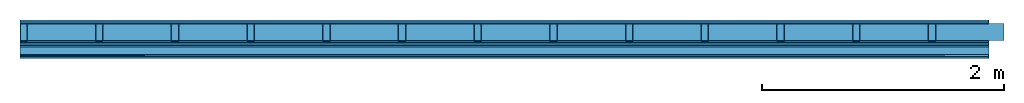
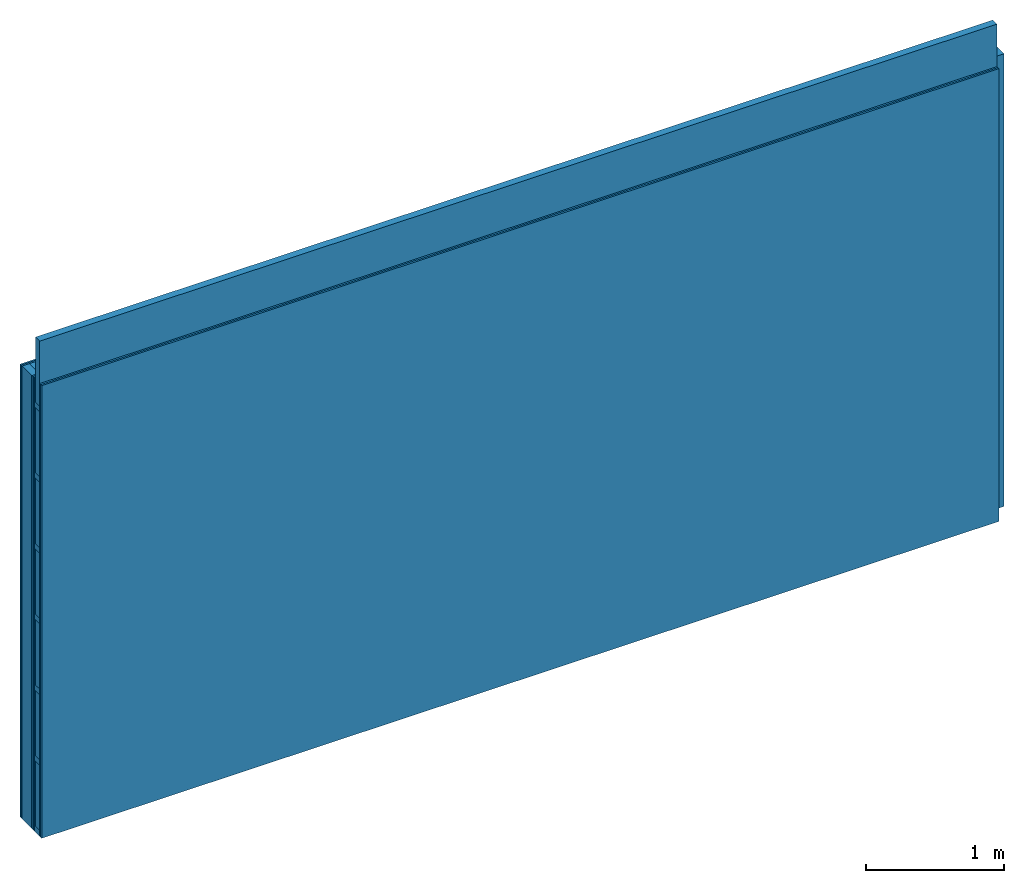
# One storey: 7 plates, 4 members, 1 element without a shape of its own.
"""IFC4 building model written with IfcOpenShell, lengths in metres."""

from ifc_helpers import new_model, si_unit, derived_unit, direction, frame, frame_2d, origin, origin_with_axes, place, context, project, spatial, rectangle, extrude, material, layer, layer_set, type_object, element, aggregate, save


model = new_model("IFC4")

# Units and contexts
plan_context = context("Plan", 3, precision=1e-05, world=origin(), true_north=direction((0.0, 1.0)))
model_context = context("Model", 3, precision=1e-05, world=origin(), true_north=direction((0.0, 1.0)))
ifc_project = project(units=[si_unit("LENGTHUNIT", "METRE"), derived_unit("SOUNDPRESSUREUNIT", [(si_unit("PRESSUREUNIT", "PASCAL", prefix="MICRO"), 0)]), si_unit("ENERGYUNIT", "JOULE", prefix="MEGA"), si_unit("MASSUNIT", "GRAM", prefix="KILO"), derived_unit("THERMALTRANSMITTANCEUNIT", [(si_unit("POWERUNIT", "WATT"), 1), (si_unit("AREAUNIT", "SQUARE_METRE"), -1), (si_unit("THERMODYNAMICTEMPERATUREUNIT", "KELVIN"), -1)]), derived_unit("AREADENSITYUNIT", [(si_unit("MASSUNIT", "GRAM", prefix="KILO"), 1), (si_unit("AREAUNIT", "SQUARE_METRE"), -1)]), derived_unit("USERDEFINED", [(si_unit("ENERGYUNIT", "JOULE", prefix="MEGA"), 1), (si_unit("AREAUNIT", "SQUARE_METRE"), -1)])], contexts=[plan_context, model_context])

# Site, building, storey
site = spatial("IfcSite", under=ifc_project)
building_placement = place(None, origin())
building = spatial("IfcBuilding", under=site, at=building_placement)
storey_placement = place(building_placement, origin())
storey = spatial("IfcBuildingStorey", under=building, at=storey_placement)

# Wall, members, plates
ifc_material_1 = material(Name="Glued joints")
ifc_layer_1 = layer(ifc_material_1, 0.0, Name="Surface")
ifc_material_2 = material(Category="03.007")
ifc_layer_2 = layer(ifc_material_2, 0.015, Name="2nd layer")
ifc_layer_3 = layer(ifc_material_2, 0.015, Name="1st layer")
ifc_material_3 = material(Name="of the art")
ifc_layer_4 = layer(ifc_material_3, 0.0, Name="Bond")
ifc_layer_5 = layer(None, 0.14, Name="Support")
ifc_layer_6 = layer(ifc_material_3, 0.0, Name="Bond")
ifc_layer_7 = layer(ifc_material_2, 0.015, Name="1st layer")
ifc_layer_8 = layer(ifc_material_2, 0.015, Name="2nd layer")
ifc_material_4 = material(Name="Air")
ifc_layer_9 = layer(ifc_material_4, 0.01, Name="Coupling")
ifc_layer_10 = layer(None, 0.075, Name="Battens / profiles")
ifc_material_5 = material(Name="Plasterboard type A", Category="03.008")
ifc_layer_11 = layer(ifc_material_5, 0.015, Name="Covering 1st layer")
ifc_layer_12 = layer(ifc_material_5, 0.015, Name="Covering 2nd layer")
ifc_material_6 = material(Name="joints", Category="04.017")
ifc_layer_13 = layer(ifc_material_6, 0.0, Name="Surface")
ifc_layer_set = layer_set([ifc_layer_1, ifc_layer_2, ifc_layer_3, ifc_layer_4, ifc_layer_5, ifc_layer_6, ifc_layer_7, ifc_layer_8, ifc_layer_9, ifc_layer_10, ifc_layer_11, ifc_layer_12, ifc_layer_13])
wall_type = type_object("IfcWallType", Name="C0095", PredefinedType="NOTDEFINED", material=ifc_layer_set)
wall_placement = place(None, frame((0.0, 0.0, 0.0), z_axis=(0.0, -1.0, 0.0), x_axis=(1.0, 0.0, 0.0)))
wall = element("IfcWall", 1, at=wall_placement, inside=storey, type_object=wall_type, material=ifc_layer_set, Name="Wall #1")
ifc_material_7 = material()
member_1_placement = place(wall_placement, origin())
member_1 = element("IfcMember", 2, at=member_1_placement, material=ifc_material_7, Name="Support", context=plan_context, shape_type="SweptSolid", body=[
    extrude(rectangle(XDim=0.06, YDim=0.14, at=frame_2d((0.03, 0.07), x_axis=(1.0, 0.0))), frame((0.0, 4.0, 0.03), z_axis=(0.0, -1.0, 0.0), x_axis=(1.0, 0.0, 0.0)), (0.0, 0.0, 1.0), 4.0),
    extrude(rectangle(XDim=0.06, YDim=0.14, at=frame_2d((0.03, 0.07), x_axis=(1.0, 0.0))), frame((0.625, 4.0, 0.03), z_axis=(0.0, -1.0, 0.0), x_axis=(1.0, 0.0, 0.0)), (0.0, 0.0, 1.0), 4.0),
    extrude(rectangle(XDim=0.06, YDim=0.14, at=frame_2d((0.03, 0.07), x_axis=(1.0, 0.0))), frame((1.25, 4.0, 0.03), z_axis=(0.0, -1.0, 0.0), x_axis=(1.0, 0.0, 0.0)), (0.0, 0.0, 1.0), 4.0),
    extrude(rectangle(XDim=0.06, YDim=0.14, at=frame_2d((0.03, 0.07), x_axis=(1.0, 0.0))), frame((1.875, 4.0, 0.03), z_axis=(0.0, -1.0, 0.0), x_axis=(1.0, 0.0, 0.0)), (0.0, 0.0, 1.0), 4.0),
    extrude(rectangle(XDim=0.06, YDim=0.14, at=frame_2d((0.03, 0.07), x_axis=(1.0, 0.0))), frame((2.5, 4.0, 0.03), z_axis=(0.0, -1.0, 0.0), x_axis=(1.0, 0.0, 0.0)), (0.0, 0.0, 1.0), 4.0),
    extrude(rectangle(XDim=0.06, YDim=0.14, at=frame_2d((0.03, 0.07), x_axis=(1.0, 0.0))), frame((3.125, 4.0, 0.03), z_axis=(0.0, -1.0, 0.0), x_axis=(1.0, 0.0, 0.0)), (0.0, 0.0, 1.0), 4.0),
    extrude(rectangle(XDim=0.06, YDim=0.14, at=frame_2d((0.03, 0.07), x_axis=(1.0, 0.0))), frame((3.75, 4.0, 0.03), z_axis=(0.0, -1.0, 0.0), x_axis=(1.0, 0.0, 0.0)), (0.0, 0.0, 1.0), 4.0),
    extrude(rectangle(XDim=0.06, YDim=0.14, at=frame_2d((0.03, 0.07), x_axis=(1.0, 0.0))), frame((4.375, 4.0, 0.03), z_axis=(0.0, -1.0, 0.0), x_axis=(1.0, 0.0, 0.0)), (0.0, 0.0, 1.0), 4.0),
    extrude(rectangle(XDim=0.06, YDim=0.14, at=frame_2d((0.03, 0.07), x_axis=(1.0, 0.0))), frame((5.0, 4.0, 0.03), z_axis=(0.0, -1.0, 0.0), x_axis=(1.0, 0.0, 0.0)), (0.0, 0.0, 1.0), 4.0),
    extrude(rectangle(XDim=0.06, YDim=0.14, at=frame_2d((0.03, 0.07), x_axis=(1.0, 0.0))), frame((5.625, 4.0, 0.03), z_axis=(0.0, -1.0, 0.0), x_axis=(1.0, 0.0, 0.0)), (0.0, 0.0, 1.0), 4.0),
    extrude(rectangle(XDim=0.06, YDim=0.14, at=frame_2d((0.03, 0.07), x_axis=(1.0, 0.0))), frame((6.25, 4.0, 0.03), z_axis=(0.0, -1.0, 0.0), x_axis=(1.0, 0.0, 0.0)), (0.0, 0.0, 1.0), 4.0),
    extrude(rectangle(XDim=0.06, YDim=0.14, at=frame_2d((0.03, 0.07), x_axis=(1.0, 0.0))), frame((6.875, 4.0, 0.03), z_axis=(0.0, -1.0, 0.0), x_axis=(1.0, 0.0, 0.0)), (0.0, 0.0, 1.0), 4.0),
    extrude(rectangle(XDim=0.06, YDim=0.14, at=frame_2d((0.03, 0.07), x_axis=(1.0, 0.0))), frame((7.5, 4.0, 0.03), z_axis=(0.0, -1.0, 0.0), x_axis=(1.0, 0.0, 0.0)), (0.0, 0.0, 1.0), 4.0),
])
ifc_material_8 = material()
member_2_placement = place(wall_placement, origin())
member_2 = element("IfcMember", 3, at=member_2_placement, material=ifc_material_8, Name="Cavity", context=plan_context, shape_type="SweptSolid", body=[
    extrude(rectangle(XDim=0.565, YDim=0.14, at=frame_2d((0.2825, 0.07), x_axis=(1.0, 0.0))), frame((0.06, 4.0, 0.03), z_axis=(0.0, -1.0, 0.0), x_axis=(1.0, 0.0, 0.0)), (0.0, 0.0, 1.0), 4.0),
    extrude(rectangle(XDim=0.565, YDim=0.14, at=frame_2d((0.2825, 0.07), x_axis=(1.0, 0.0))), frame((0.685, 4.0, 0.03), z_axis=(0.0, -1.0, 0.0), x_axis=(1.0, 0.0, 0.0)), (0.0, 0.0, 1.0), 4.0),
    extrude(rectangle(XDim=0.565, YDim=0.14, at=frame_2d((0.2825, 0.07), x_axis=(1.0, 0.0))), frame((1.31, 4.0, 0.03), z_axis=(0.0, -1.0, 0.0), x_axis=(1.0, 0.0, 0.0)), (0.0, 0.0, 1.0), 4.0),
    extrude(rectangle(XDim=0.565, YDim=0.14, at=frame_2d((0.2825, 0.07), x_axis=(1.0, 0.0))), frame((1.935, 4.0, 0.03), z_axis=(0.0, -1.0, 0.0), x_axis=(1.0, 0.0, 0.0)), (0.0, 0.0, 1.0), 4.0),
    extrude(rectangle(XDim=0.565, YDim=0.14, at=frame_2d((0.2825, 0.07), x_axis=(1.0, 0.0))), frame((2.56, 4.0, 0.03), z_axis=(0.0, -1.0, 0.0), x_axis=(1.0, 0.0, 0.0)), (0.0, 0.0, 1.0), 4.0),
    extrude(rectangle(XDim=0.565, YDim=0.14, at=frame_2d((0.2825, 0.07), x_axis=(1.0, 0.0))), frame((3.185, 4.0, 0.03), z_axis=(0.0, -1.0, 0.0), x_axis=(1.0, 0.0, 0.0)), (0.0, 0.0, 1.0), 4.0),
    extrude(rectangle(XDim=0.565, YDim=0.14, at=frame_2d((0.2825, 0.07), x_axis=(1.0, 0.0))), frame((3.81, 4.0, 0.03), z_axis=(0.0, -1.0, 0.0), x_axis=(1.0, 0.0, 0.0)), (0.0, 0.0, 1.0), 4.0),
    extrude(rectangle(XDim=0.565, YDim=0.14, at=frame_2d((0.2825, 0.07), x_axis=(1.0, 0.0))), frame((4.435, 4.0, 0.03), z_axis=(0.0, -1.0, 0.0), x_axis=(1.0, 0.0, 0.0)), (0.0, 0.0, 1.0), 4.0),
    extrude(rectangle(XDim=0.565, YDim=0.14, at=frame_2d((0.2825, 0.07), x_axis=(1.0, 0.0))), frame((5.06, 4.0, 0.03), z_axis=(0.0, -1.0, 0.0), x_axis=(1.0, 0.0, 0.0)), (0.0, 0.0, 1.0), 4.0),
    extrude(rectangle(XDim=0.565, YDim=0.14, at=frame_2d((0.2825, 0.07), x_axis=(1.0, 0.0))), frame((5.685, 4.0, 0.03), z_axis=(0.0, -1.0, 0.0), x_axis=(1.0, 0.0, 0.0)), (0.0, 0.0, 1.0), 4.0),
    extrude(rectangle(XDim=0.565, YDim=0.14, at=frame_2d((0.2825, 0.07), x_axis=(1.0, 0.0))), frame((6.31, 4.0, 0.03), z_axis=(0.0, -1.0, 0.0), x_axis=(1.0, 0.0, 0.0)), (0.0, 0.0, 1.0), 4.0),
    extrude(rectangle(XDim=0.565, YDim=0.14, at=frame_2d((0.2825, 0.07), x_axis=(1.0, 0.0))), frame((6.935, 4.0, 0.03), z_axis=(0.0, -1.0, 0.0), x_axis=(1.0, 0.0, 0.0)), (0.0, 0.0, 1.0), 4.0),
    extrude(rectangle(XDim=0.565, YDim=0.14, at=frame_2d((0.2825, 0.07), x_axis=(1.0, 0.0))), frame((7.56, 4.0, 0.03), z_axis=(0.0, -1.0, 0.0), x_axis=(1.0, 0.0, 0.0)), (0.0, 0.0, 1.0), 4.0),
])
ifc_material_9 = material()
member_3_placement = place(wall_placement, origin())
member_3 = element("IfcMember", 4, at=member_3_placement, material=ifc_material_9, Name="Battens / profiles", context=plan_context, shape_type="SweptSolid", body=[
    extrude(rectangle(XDim=0.05, YDim=0.075, at=frame_2d((0.025, 0.0375), x_axis=(1.0, 0.0))), frame((0.0, 0.0, 0.21), z_axis=(1.0, 0.0, 0.0), x_axis=(0.0, 1.0, 0.0)), (0.0, 0.0, 1.0), 8.0),
    extrude(rectangle(XDim=0.05, YDim=0.075, at=frame_2d((0.025, 0.0375), x_axis=(1.0, 0.0))), frame((0.0, 0.625, 0.21), z_axis=(1.0, 0.0, 0.0), x_axis=(0.0, 1.0, 0.0)), (0.0, 0.0, 1.0), 8.0),
    extrude(rectangle(XDim=0.05, YDim=0.075, at=frame_2d((0.025, 0.0375), x_axis=(1.0, 0.0))), frame((0.0, 1.25, 0.21), z_axis=(1.0, 0.0, 0.0), x_axis=(0.0, 1.0, 0.0)), (0.0, 0.0, 1.0), 8.0),
    extrude(rectangle(XDim=0.05, YDim=0.075, at=frame_2d((0.025, 0.0375), x_axis=(1.0, 0.0))), frame((0.0, 1.875, 0.21), z_axis=(1.0, 0.0, 0.0), x_axis=(0.0, 1.0, 0.0)), (0.0, 0.0, 1.0), 8.0),
    extrude(rectangle(XDim=0.05, YDim=0.075, at=frame_2d((0.025, 0.0375), x_axis=(1.0, 0.0))), frame((0.0, 2.5, 0.21), z_axis=(1.0, 0.0, 0.0), x_axis=(0.0, 1.0, 0.0)), (0.0, 0.0, 1.0), 8.0),
    extrude(rectangle(XDim=0.05, YDim=0.075, at=frame_2d((0.025, 0.0375), x_axis=(1.0, 0.0))), frame((0.0, 3.125, 0.21), z_axis=(1.0, 0.0, 0.0), x_axis=(0.0, 1.0, 0.0)), (0.0, 0.0, 1.0), 8.0),
    extrude(rectangle(XDim=0.05, YDim=0.075, at=frame_2d((0.025, 0.0375), x_axis=(1.0, 0.0))), frame((0.0, 3.75, 0.21), z_axis=(1.0, 0.0, 0.0), x_axis=(0.0, 1.0, 0.0)), (0.0, 0.0, 1.0), 8.0),
])
member_4_placement = place(wall_placement, origin())
member_4 = element("IfcMember", 5, at=member_4_placement, material=ifc_material_8, Name="Cavity", context=plan_context, shape_type="SweptSolid", body=[
    extrude(rectangle(XDim=0.575, YDim=0.06, at=frame_2d((0.2875, 0.03), x_axis=(1.0, 0.0))), frame((0.0, 0.05, 0.225), z_axis=(1.0, 0.0, 0.0), x_axis=(0.0, 1.0, 0.0)), (0.0, 0.0, 1.0), 8.0),
    extrude(rectangle(XDim=0.575, YDim=0.06, at=frame_2d((0.2875, 0.03), x_axis=(1.0, 0.0))), frame((0.0, 0.675, 0.225), z_axis=(1.0, 0.0, 0.0), x_axis=(0.0, 1.0, 0.0)), (0.0, 0.0, 1.0), 8.0),
    extrude(rectangle(XDim=0.575, YDim=0.06, at=frame_2d((0.2875, 0.03), x_axis=(1.0, 0.0))), frame((0.0, 1.3, 0.225), z_axis=(1.0, 0.0, 0.0), x_axis=(0.0, 1.0, 0.0)), (0.0, 0.0, 1.0), 8.0),
    extrude(rectangle(XDim=0.575, YDim=0.06, at=frame_2d((0.2875, 0.03), x_axis=(1.0, 0.0))), frame((0.0, 1.925, 0.225), z_axis=(1.0, 0.0, 0.0), x_axis=(0.0, 1.0, 0.0)), (0.0, 0.0, 1.0), 8.0),
    extrude(rectangle(XDim=0.575, YDim=0.06, at=frame_2d((0.2875, 0.03), x_axis=(1.0, 0.0))), frame((0.0, 2.55, 0.225), z_axis=(1.0, 0.0, 0.0), x_axis=(0.0, 1.0, 0.0)), (0.0, 0.0, 1.0), 8.0),
    extrude(rectangle(XDim=0.575, YDim=0.06, at=frame_2d((0.2875, 0.03), x_axis=(1.0, 0.0))), frame((0.0, 3.175, 0.225), z_axis=(1.0, 0.0, 0.0), x_axis=(0.0, 1.0, 0.0)), (0.0, 0.0, 1.0), 8.0),
    extrude(rectangle(XDim=0.575, YDim=0.06, at=frame_2d((0.2875, 0.03), x_axis=(1.0, 0.0))), frame((0.0, 3.8, 0.225), z_axis=(1.0, 0.0, 0.0), x_axis=(0.0, 1.0, 0.0)), (0.0, 0.0, 1.0), 8.0),
])
plate_1_placement = place(wall_placement, origin())
plate_1 = element("IfcPlate", 6, at=plate_1_placement, material=ifc_material_2, Name="2nd layer", context=plan_context, shape_type="SweptSolid", body=[
    extrude(rectangle(XDim=8.0, YDim=4.0, at=frame_2d((4.0, 2.0), x_axis=(1.0, 0.0))), origin_with_axes(), (0.0, 0.0, 1.0), 0.015),
])
plate_2_placement = place(wall_placement, origin())
plate_2 = element("IfcPlate", 7, at=plate_2_placement, material=ifc_material_2, Name="1st layer", context=plan_context, shape_type="SweptSolid", body=[
    extrude(rectangle(XDim=8.0, YDim=4.0, at=frame_2d((4.0, 2.0), x_axis=(1.0, 0.0))), frame((0.0, 0.0, 0.015), z_axis=(0.0, 0.0, 1.0), x_axis=(1.0, 0.0, 0.0)), (0.0, 0.0, 1.0), 0.015),
])
plate_3_placement = place(wall_placement, origin())
plate_3 = element("IfcPlate", 8, at=plate_3_placement, material=ifc_material_2, Name="1st layer", context=plan_context, shape_type="SweptSolid", body=[
    extrude(rectangle(XDim=8.0, YDim=4.0, at=frame_2d((4.0, 2.0), x_axis=(1.0, 0.0))), frame((0.0, 0.0, 0.17), z_axis=(0.0, 0.0, 1.0), x_axis=(1.0, 0.0, 0.0)), (0.0, 0.0, 1.0), 0.015),
])
plate_4_placement = place(wall_placement, origin())
plate_4 = element("IfcPlate", 9, at=plate_4_placement, material=ifc_material_2, Name="2nd layer", context=plan_context, shape_type="SweptSolid", body=[
    extrude(rectangle(XDim=8.0, YDim=4.0, at=frame_2d((4.0, 2.0), x_axis=(1.0, 0.0))), frame((0.0, 0.0, 0.185), z_axis=(0.0, 0.0, 1.0), x_axis=(1.0, 0.0, 0.0)), (0.0, 0.0, 1.0), 0.015),
])
plate_5_placement = place(wall_placement, origin())
plate_5 = element("IfcPlate", 10, at=plate_5_placement, material=ifc_material_4, Name="Coupling", context=plan_context, shape_type="SweptSolid", body=[
    extrude(rectangle(XDim=8.0, YDim=4.0, at=frame_2d((4.0, 2.0), x_axis=(1.0, 0.0))), frame((0.0, 0.0, 0.2), z_axis=(0.0, 0.0, 1.0), x_axis=(1.0, 0.0, 0.0)), (0.0, 0.0, 1.0), 0.01),
])
plate_6_placement = place(wall_placement, origin())
plate_6 = element("IfcPlate", 11, at=plate_6_placement, material=ifc_material_5, Name="Covering 1st layer", context=plan_context, shape_type="SweptSolid", body=[
    extrude(rectangle(XDim=8.0, YDim=4.0, at=frame_2d((4.0, 2.0), x_axis=(1.0, 0.0))), frame((0.0, 0.0, 0.285), z_axis=(0.0, 0.0, 1.0), x_axis=(1.0, 0.0, 0.0)), (0.0, 0.0, 1.0), 0.015),
])
plate_7_placement = place(wall_placement, origin())
plate_7 = element("IfcPlate", 12, at=plate_7_placement, material=ifc_material_5, Name="Covering 2nd layer", context=plan_context, shape_type="SweptSolid", body=[
    extrude(rectangle(XDim=8.0, YDim=4.0, at=frame_2d((4.0, 2.0), x_axis=(1.0, 0.0))), frame((0.0, 0.0, 0.3), z_axis=(0.0, 0.0, 1.0), x_axis=(1.0, 0.0, 0.0)), (0.0, 0.0, 1.0), 0.015),
])
aggregate(wall, [plate_1, plate_2, member_1, member_2, plate_3, plate_4, plate_5, member_3, member_4, plate_6, plate_7])

save(model, "model.ifc")
